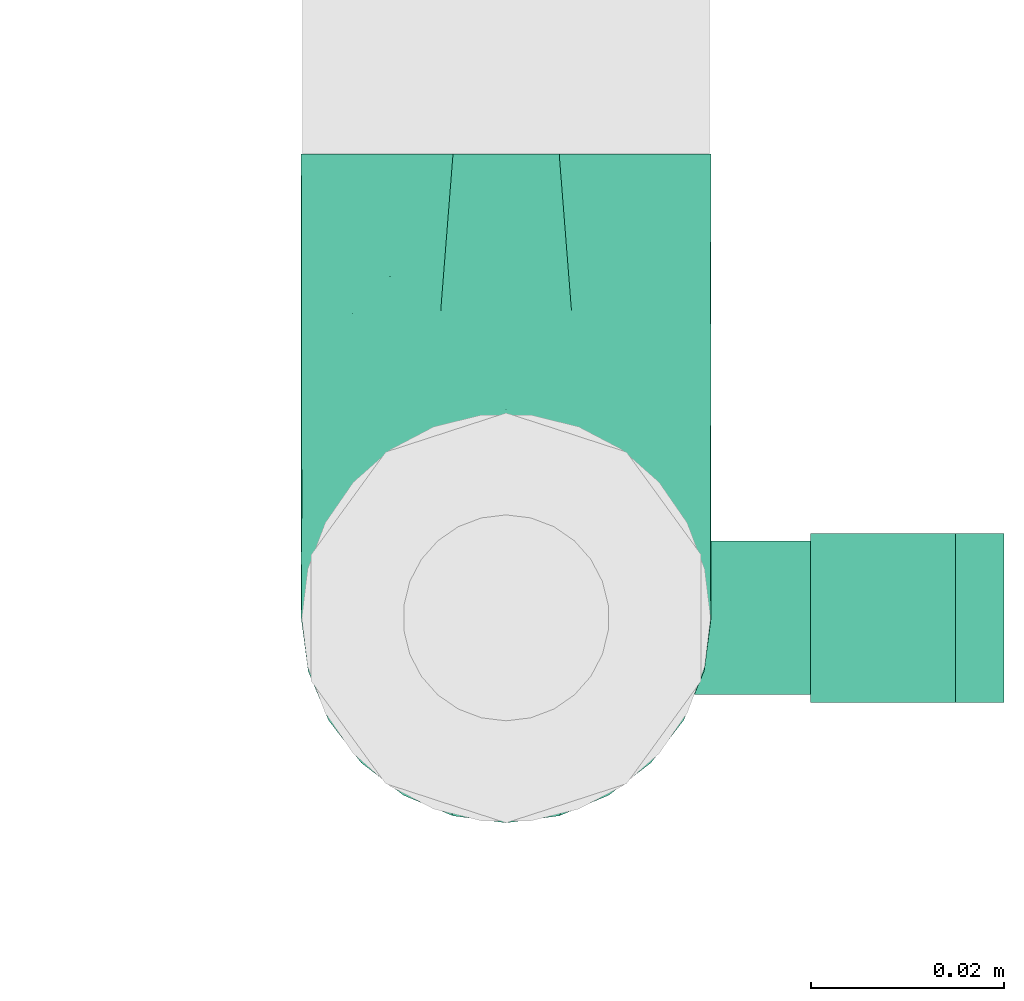
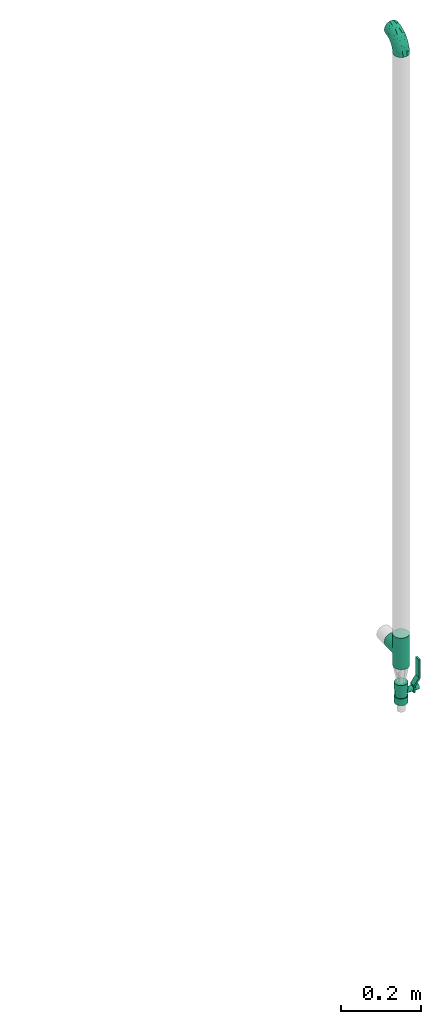
# One storey, part 76 of 93: 2 flow fittings, 1 flow controller.
"""IFC2X3 building model written with IfcOpenShell, lengths in millimetres."""

from ifc_helpers import new_model, entity, si_unit, converted_unit, derived_unit, direction, frame, origin, origin_2d_with_axis, place, context, subcontext, project, spatial, polyline, circle, outline, extrude, faceted_brep, source, transform, mapped, material, material_list, type_object, type_shapes, element, save


model = new_model("IFC2X3")

# Units and contexts
model_context = context("Model", 3, precision=0.01, world=origin(), true_north=direction((6.12303176911189e-17, 1.0)))
body_context = subcontext(model_context, "Body", "Model", "MODEL_VIEW")
ifc_project = project(units=[si_unit("LENGTHUNIT", "METRE", prefix="MILLI"), si_unit("AREAUNIT", "SQUARE_METRE"), si_unit("VOLUMEUNIT", "CUBIC_METRE"), converted_unit("PLANEANGLEUNIT", "DEGREE", entity("IfcRatioMeasure", 0.0174532925199433), si_unit("PLANEANGLEUNIT", "RADIAN"), dimensions=[0, 0, 0, 0, 0, 0, 0]), si_unit("MASSUNIT", "GRAM", prefix="KILO"), derived_unit("MASSDENSITYUNIT", [(si_unit("MASSUNIT", "GRAM", prefix="KILO"), 1), (si_unit("LENGTHUNIT", "METRE"), -3)]), derived_unit("MOMENTOFINERTIAUNIT", [(si_unit("LENGTHUNIT", "METRE"), 4)]), si_unit("TIMEUNIT", "SECOND"), si_unit("FREQUENCYUNIT", "HERTZ"), si_unit("THERMODYNAMICTEMPERATUREUNIT", "DEGREE_CELSIUS"), derived_unit("THERMALTRANSMITTANCEUNIT", [(si_unit("MASSUNIT", "GRAM", prefix="KILO"), 1), (si_unit("THERMODYNAMICTEMPERATUREUNIT", "KELVIN"), -1), (si_unit("TIMEUNIT", "SECOND"), -3)]), derived_unit("VOLUMETRICFLOWRATEUNIT", [(si_unit("LENGTHUNIT", "METRE"), 3), (si_unit("TIMEUNIT", "SECOND"), -1)]), derived_unit("MASSFLOWRATEUNIT", [(si_unit("MASSUNIT", "GRAM", prefix="KILO"), 1), (si_unit("TIMEUNIT", "SECOND"), -1)]), derived_unit("ROTATIONALFREQUENCYUNIT", [(si_unit("TIMEUNIT", "SECOND"), -1)]), si_unit("ELECTRICCURRENTUNIT", "AMPERE"), si_unit("ELECTRICVOLTAGEUNIT", "VOLT"), si_unit("POWERUNIT", "WATT"), si_unit("FORCEUNIT", "NEWTON", prefix="KILO"), si_unit("ILLUMINANCEUNIT", "LUX"), si_unit("LUMINOUSFLUXUNIT", "LUMEN"), si_unit("LUMINOUSINTENSITYUNIT", "CANDELA"), derived_unit("USERDEFINED", [(si_unit("MASSUNIT", "GRAM", prefix="KILO"), -1), (si_unit("LENGTHUNIT", "METRE"), -2), (si_unit("TIMEUNIT", "SECOND"), 3), (si_unit("LUMINOUSFLUXUNIT", "LUMEN"), 1)]), derived_unit("LINEARVELOCITYUNIT", [(si_unit("LENGTHUNIT", "METRE"), 1), (si_unit("TIMEUNIT", "SECOND"), -1)]), si_unit("PRESSUREUNIT", "PASCAL"), derived_unit("USERDEFINED", [(si_unit("LENGTHUNIT", "METRE"), -2), (si_unit("MASSUNIT", "GRAM", prefix="KILO"), 1), (si_unit("TIMEUNIT", "SECOND"), -2)]), derived_unit("LINEARFORCEUNIT", [(si_unit("MASSUNIT", "GRAM", prefix="KILO"), 1), (si_unit("LENGTHUNIT", "METRE"), 1), (si_unit("TIMEUNIT", "SECOND"), -2), (si_unit("LENGTHUNIT", "METRE"), -1)]), derived_unit("PLANARFORCEUNIT", [(si_unit("MASSUNIT", "GRAM", prefix="KILO"), 1), (si_unit("LENGTHUNIT", "METRE"), 1), (si_unit("TIMEUNIT", "SECOND"), -2), (si_unit("LENGTHUNIT", "METRE"), -2)])], contexts=[model_context])

# Site, building, storey
site_placement = place(None, origin())
site = spatial("IfcSite", under=ifc_project, at=site_placement, CompositionType="ELEMENT")
building_placement = place(site_placement, origin())
building = spatial("IfcBuilding", under=site, at=building_placement, CompositionType="ELEMENT")
storey_placement = place(building_placement, frame((0.0, 0.0, -4200.0)))
storey = spatial("IfcBuildingStorey", under=building, at=storey_placement, CompositionType="ELEMENT", Elevation=-4200.0)

# Flow controller
ifc_material = material()
ifc_material_list = material_list([ifc_material, ifc_material, ifc_material, ifc_material, ifc_material])
valve_type = type_object("IfcValveType", PredefinedType="NOTDEFINED", material=ifc_material_list)
shared_shape_1 = source(origin(), body_context, "Body", "SweptSolid", [
    extrude(circle(Radius=17.5, at=origin_2d_with_axis()), frame((-30.5, 0.0, 0.0), z_axis=(1.0, 0.0, 0.0), x_axis=(0.0, 1.0, 0.0)), (0.0, 0.0, 1.0), 20.3333333333333),
    extrude(circle(Radius=16.0, at=origin_2d_with_axis()), frame((-10.17, 0.0, 0.0), z_axis=(1.0, 0.0, 0.0), x_axis=(0.0, 1.0, 0.0)), (0.0, 0.0, 1.0), 20.3333333333333),
    extrude(circle(Radius=17.5, at=origin_2d_with_axis()), frame((10.17, 0.0, 0.0), z_axis=(1.0, 0.0, 0.0), x_axis=(0.0, 1.0, 0.0)), (0.0, 0.0, 1.0), 20.3333333333333),
    extrude(outline(polyline([(-38.75, -5.0), (-38.75, -10.0), (-17.92, -10.0), (2.08, 5.0), (56.25, 5.0), (56.25, 10.0), (0.42, 10.0), (-19.58, -5.0), (-38.75, -5.0)])), frame((28.75, -8.75, 41.5), z_axis=(0.0, -1.0, 0.0), x_axis=(1.0, 0.0, 0.0)), (0.0, 0.0, -1.0), 17.5),
    extrude(circle(Radius=8.0, at=origin_2d_with_axis()), origin(), (0.0, 0.0, 1.0), 49.0),
])
type_shapes(valve_type, [shared_shape_1])
flow_controller_placement = place(storey_placement, frame((60113.17, 18671.47, 32740.0), z_axis=(1.0, 0.0, 0.0), x_axis=(0.0, 0.0, 1.0)))
element("IfcFlowController", 1, at=flow_controller_placement, inside=storey, type_object=valve_type, material=ifc_material, context=body_context, shape_type="MappedRepresentation", body=[
    mapped(shared_shape_1, transform((0.0, 0.0, 0.0), scale=1.0)),
])

# Flow fittings
pipe_fitting_type_1 = type_object("IfcPipeFittingType", Name="ADSK_1", PredefinedType="NOTDEFINED", material=ifc_material)
shared_shape_2 = source(origin(), body_context, "Body", "Brep", [
    faceted_brep([(-48.0, 10.6, -18.36), (-48.0, 5.49, -20.48), (-48.0, 0.0, -21.2), (-48.0, -5.49, -20.48), (-48.0, -10.6, -18.36), (-48.0, -14.99, -14.99), (-48.0, -18.36, -10.6), (-48.0, -20.48, -5.49), (-48.0, -21.2, 0.0), (-48.0, -20.48, 5.49), (-48.0, -18.36, 10.6), (-48.0, -14.99, 14.99), (-48.0, -10.6, 18.36), (-48.0, -5.49, 20.48), (-48.0, 0.0, 21.2), (-48.0, 5.49, 20.48), (-48.0, 10.6, 18.36), (-48.0, 14.99, 14.99), (-48.0, 18.36, 10.6), (-48.0, 20.48, 5.49), (-48.0, 21.2, 0.0), (-48.0, 20.48, -5.49), (-48.0, 18.36, -10.6), (-48.0, 14.99, -14.99), (0.0, 48.0, -21.2), (-5.49, 48.0, -20.48), (-10.6, 48.0, -18.36), (-14.99, 48.0, -14.99), (-18.36, 48.0, -10.6), (-20.48, 48.0, -5.49), (-21.2, 48.0, 0.0), (-20.48, 48.0, 5.49), (-18.36, 48.0, 10.6), (-14.99, 48.0, 14.99), (-10.6, 48.0, 18.36), (-5.49, 48.0, 20.48), (0.0, 48.0, 21.2), (5.49, 48.0, 20.48), (10.6, 48.0, 18.36), (14.99, 48.0, 14.99), (18.36, 48.0, 10.6), (20.48, 48.0, 5.49), (21.2, 48.0, 0.0), (20.48, 48.0, -5.49), (18.36, 48.0, -10.6), (14.99, 48.0, -14.99), (10.6, 48.0, -18.36), (5.49, 48.0, -20.48), (-35.25, -16.22, 12.01), (-34.76, -18.57, 0.0), (-20.87, -12.37, 10.9), (-31.49, -11.78, 15.9), (-37.0, -2.58, 20.86), (-33.89, 3.62, 21.15), (-31.81, -18.14, 6.76), (-5.78, 5.78, 17.67), (-19.42, -4.1, 17.86), (-9.6, -3.39, 13.73), (-35.44, -7.73, 19.13), (11.78, 31.49, 15.9), (-5.93, -5.46, 6.95), (-18.45, -13.78, 5.46), (-10.29, -8.43, 0.0), (-24.6, 0.55, 20.62), (-37.28, 17.94, 13.81), (-33.38, 22.85, 9.59), (-41.46, 20.06, 8.75), (-29.51, 20.45, 15.16), (-15.04, 10.79, 21.13), (-7.08, 16.98, 20.93), (-8.39, 23.51, 21.15), (-40.86, 13.03, 17.26), (-8.05, 41.26, 19.83), (-3.21, 35.97, 21.14), (8.53, 19.66, 14.74), (4.1, 19.42, 17.86), (-37.72, 22.66, 4.78), (-37.07, 8.58, 19.98), (-13.0, 5.43, 19.97), (-3.78, 13.93, 19.7), (3.02, 8.69, 13.43), (-2.27, -0.05, 10.65), (6.22, 6.99, 7.09), (-22.25, 34.6, 9.45), (18.14, 31.81, 6.76), (16.22, 35.25, 12.01), (12.37, 20.87, 10.9), (7.73, 35.44, 19.13), (-21.52, -15.93, 0.0), (2.58, 37.0, 20.86), (18.57, 34.76, 0.0), (13.78, 18.45, 5.46), (15.93, 21.52, 0.0), (-20.03, -8.54, 14.9), (-28.6, 28.6, 5.16), (-24.79, 34.6, 0.0), (-34.6, 24.79, 0.0), (-22.81, 37.41, 4.68), (-23.36, 26.33, 14.79), (-13.68, 37.05, 17.49), (-17.72, 38.12, 13.73), (-26.25, 27.3, 11.24), (-9.71, 32.34, 20.14), (-17.26, 25.6, 18.71), (-26.33, 9.99, 20.77), (-24.06, 6.05, 21.2), (-25.02, 15.46, 19.56), (-24.3, 20.72, 17.57), (-31.95, 15.23, 17.8), (-13.53, 24.7, 20.21), (-17.6, 17.6, 20.6), (-0.55, 24.6, 20.62), (-11.41, -7.48, 10.43), (0.93, -0.93, 0.0), (8.43, 10.29, 0.0), (-11.41, -7.48, -10.43), (-20.1, -8.84, -14.66), (-9.6, -3.39, -13.73), (7.73, 35.44, -19.13), (4.1, 19.42, -17.86), (-0.55, 24.6, -20.62), (-38.12, 17.72, -13.73), (-37.05, 13.68, -17.49), (-32.34, 9.71, -20.14), (-41.26, 8.05, -19.83), (-37.41, 22.81, -4.68), (-23.51, 8.39, -21.15), (-35.97, 3.21, -21.14), (-28.6, 28.6, -5.16), (-31.81, -18.14, -6.76), (-18.45, -13.78, -5.46), (-25.6, 17.26, -18.71), (-19.42, -4.1, -17.86), (-17.94, 37.28, -13.81), (-22.85, 33.38, -9.59), (-20.06, 41.46, -8.75), (-31.49, -11.78, -15.9), (-35.25, -16.22, -12.01), (8.53, 19.66, -14.74), (11.78, 31.49, -15.9), (-9.99, 26.33, -20.77), (-6.05, 24.06, -21.2), (-10.79, 15.04, -21.13), (-37.0, -2.58, -20.86), (-16.98, 7.08, -20.93), (-5.43, 13.0, -19.97), (-13.93, 3.78, -19.7), (-20.87, -12.37, -10.9), (-26.33, 23.36, -14.79), (-22.66, 37.72, -4.78), (13.78, 18.45, -5.46), (18.14, 31.81, -6.76), (-15.46, 25.02, -19.56), (-20.72, 24.3, -17.57), (16.22, 35.25, -12.01), (-13.03, 40.86, -17.26), (-8.58, 37.07, -19.98), (2.58, 37.0, -20.86), (-3.62, 33.89, -21.15), (-34.6, 22.25, -9.45), (6.22, 6.99, -7.09), (-20.45, 29.51, -15.16), (-35.44, -7.73, -19.13), (12.37, 20.87, -10.9), (-27.3, 26.25, -11.24), (-15.23, 31.95, -17.8), (-24.7, 13.53, -20.21), (-24.6, 0.55, -20.62), (-5.78, 5.78, -17.67), (-17.6, 17.6, -20.6), (3.02, 8.69, -13.43), (-5.93, -5.46, -6.95), (-2.27, -0.05, -10.65)], [[[0, 1, 2, 3, 4, 5, 6, 7, 8, 9, 10, 11, 12, 13, 14, 15, 16, 17, 18, 19, 20, 21, 22, 23]], [[24, 25, 26, 27, 28, 29, 30, 31, 32, 33, 34, 35, 36, 37, 38, 39, 40, 41, 42, 43, 44, 45, 46, 47]], [[10, 48, 11]], [[9, 8, 49]], [[48, 50, 51]], [[14, 52, 53]], [[10, 54, 48]], [[9, 54, 10]], [[55, 56, 57]], [[51, 12, 11]], [[51, 58, 12]], [[59, 39, 38]], [[60, 61, 62]], [[58, 56, 63]], [[64, 65, 66]], [[67, 65, 64]], [[68, 69, 70]], [[16, 71, 17]], [[13, 52, 14]], [[35, 72, 73]], [[14, 53, 15]], [[17, 64, 18]], [[74, 59, 75]], [[20, 19, 76]], [[66, 19, 18]], [[77, 15, 53]], [[15, 77, 16]], [[69, 78, 79]], [[80, 81, 82]], [[32, 31, 83]], [[84, 85, 86]], [[59, 87, 75]], [[61, 54, 88]], [[36, 89, 37]], [[84, 41, 40]], [[36, 35, 73]], [[90, 41, 84]], [[40, 39, 85]], [[12, 58, 13]], [[85, 84, 40]], [[91, 84, 86]], [[84, 92, 90]], [[87, 38, 37]], [[93, 56, 51]], [[65, 94, 76]], [[94, 95, 96]], [[84, 91, 92]], [[95, 97, 30]], [[98, 99, 100]], [[76, 94, 96]], [[101, 98, 83]], [[100, 99, 33]], [[102, 70, 73]], [[103, 102, 99]], [[94, 97, 95]], [[72, 99, 102]], [[72, 35, 34]], [[34, 33, 99]], [[9, 49, 54]], [[87, 59, 38]], [[104, 105, 68]], [[106, 103, 107]], [[106, 77, 104]], [[71, 64, 17]], [[108, 107, 67]], [[33, 32, 100]], [[109, 103, 110]], [[102, 109, 70]], [[89, 73, 111]], [[50, 48, 54]], [[51, 11, 48]], [[56, 58, 51]], [[88, 54, 49]], [[52, 58, 63]], [[50, 112, 93]], [[56, 55, 78]], [[39, 59, 85]], [[86, 85, 59]], [[89, 87, 37]], [[42, 41, 90]], [[111, 79, 75]], [[111, 75, 87]], [[75, 55, 80]], [[104, 77, 53]], [[71, 77, 108]], [[32, 83, 100]], [[98, 100, 83]], [[99, 98, 103]], [[106, 107, 108]], [[68, 70, 110]], [[111, 73, 70]], [[68, 110, 104]], [[68, 63, 78]], [[57, 93, 112]], [[80, 55, 57]], [[61, 50, 54]], [[80, 82, 86]], [[81, 57, 112]], [[74, 86, 59]], [[60, 113, 82]], [[82, 114, 91]], [[101, 94, 65]], [[97, 94, 83]], [[73, 89, 36]], [[87, 89, 111]], [[58, 52, 13]], [[53, 52, 63]], [[104, 53, 105]], [[106, 104, 110]], [[20, 76, 96]], [[76, 19, 66]], [[103, 106, 110]], [[77, 106, 108]], [[103, 98, 107]], [[67, 107, 98]], [[67, 98, 101]], [[108, 67, 64]], [[53, 63, 105]], [[63, 68, 105]], [[83, 31, 97]], [[30, 97, 31]], [[62, 113, 60]], [[112, 61, 60]], [[61, 88, 62]], [[86, 82, 91]], [[56, 78, 63]], [[114, 82, 113]], [[114, 92, 91]], [[79, 78, 55]], [[75, 79, 55]], [[69, 79, 111]], [[70, 69, 111]], [[78, 69, 68]], [[77, 71, 16]], [[64, 71, 108]], [[64, 66, 18]], [[76, 66, 65]], [[99, 72, 34]], [[73, 72, 102]], [[94, 101, 83]], [[67, 101, 65]], [[75, 80, 74]], [[80, 86, 74]], [[70, 109, 110]], [[102, 103, 109]], [[50, 93, 51]], [[57, 56, 93]], [[61, 112, 50]], [[81, 112, 60]], [[82, 81, 60]], [[80, 57, 81]], [[115, 116, 117]], [[118, 119, 120]], [[121, 122, 23]], [[123, 124, 122]], [[96, 125, 20]], [[123, 126, 127]], [[128, 96, 95]], [[129, 130, 88]], [[123, 122, 131]], [[116, 132, 117]], [[133, 134, 135]], [[0, 124, 1]], [[5, 136, 137]], [[138, 119, 139]], [[129, 88, 49]], [[140, 141, 142]], [[6, 5, 137]], [[46, 118, 47]], [[143, 3, 2]], [[144, 145, 146]], [[6, 129, 7]], [[129, 137, 147]], [[127, 2, 1]], [[148, 122, 121]], [[128, 125, 96]], [[134, 128, 149]], [[95, 149, 128]], [[150, 151, 92]], [[30, 29, 149]], [[152, 131, 153]], [[27, 133, 28]], [[154, 45, 44]], [[136, 5, 4]], [[27, 26, 155]], [[156, 26, 25]], [[24, 157, 158]], [[24, 47, 157]], [[22, 21, 159]], [[160, 150, 114]], [[134, 133, 161]], [[142, 144, 126]], [[46, 139, 118]], [[162, 136, 4]], [[156, 25, 158]], [[1, 124, 127]], [[115, 147, 116]], [[45, 154, 139]], [[139, 46, 45]], [[154, 163, 139]], [[162, 4, 3]], [[42, 90, 43]], [[130, 129, 147]], [[49, 7, 129]], [[43, 151, 44]], [[0, 23, 122]], [[24, 158, 25]], [[136, 162, 132]], [[135, 29, 28]], [[43, 90, 151]], [[164, 148, 159]], [[152, 156, 140]], [[155, 133, 27]], [[165, 153, 161]], [[23, 22, 121]], [[123, 131, 166]], [[123, 166, 126]], [[143, 127, 167]], [[147, 137, 136]], [[8, 7, 49]], [[129, 6, 137]], [[143, 162, 3]], [[167, 146, 132]], [[167, 132, 162]], [[132, 168, 117]], [[44, 151, 154]], [[92, 151, 90]], [[163, 154, 151]], [[119, 118, 139]], [[157, 118, 120]], [[138, 139, 163]], [[119, 168, 145]], [[140, 156, 158]], [[155, 156, 165]], [[22, 159, 121]], [[148, 121, 159]], [[122, 148, 131]], [[152, 153, 165]], [[142, 126, 169]], [[167, 127, 126]], [[142, 169, 140]], [[142, 120, 145]], [[168, 170, 117]], [[160, 171, 172]], [[115, 172, 171]], [[171, 62, 130]], [[119, 170, 168]], [[170, 163, 160]], [[150, 163, 151]], [[113, 171, 160]], [[164, 128, 134]], [[125, 128, 159]], [[127, 143, 2]], [[162, 143, 167]], [[118, 157, 47]], [[158, 157, 120]], [[140, 158, 141]], [[152, 140, 169]], [[30, 149, 95]], [[149, 29, 135]], [[131, 152, 169]], [[156, 152, 165]], [[131, 148, 153]], [[161, 153, 148]], [[161, 148, 164]], [[165, 161, 133]], [[158, 120, 141]], [[120, 142, 141]], [[159, 21, 125]], [[20, 125, 21]], [[115, 130, 147]], [[114, 113, 160]], [[62, 171, 113]], [[62, 88, 130]], [[160, 163, 150]], [[150, 92, 114]], [[119, 145, 120]], [[146, 145, 168]], [[132, 146, 168]], [[144, 146, 167]], [[126, 144, 167]], [[145, 144, 142]], [[156, 155, 26]], [[133, 155, 165]], [[133, 135, 28]], [[149, 135, 134]], [[122, 124, 0]], [[127, 124, 123]], [[128, 164, 159]], [[161, 164, 134]], [[163, 170, 138]], [[170, 119, 138]], [[131, 169, 166]], [[126, 166, 169]], [[147, 136, 116]], [[132, 116, 136]], [[172, 115, 117]], [[130, 115, 171]], [[117, 170, 172]], [[160, 172, 170]]]),
])
type_shapes(pipe_fitting_type_1, [shared_shape_2])
flow_fitting_1_placement = place(storey_placement, frame((60113.17, 18671.47, 34734.74), z_axis=(-1.0, 0.0, 0.0), x_axis=(0.0, 0.0, 1.0)))
element("IfcFlowFitting", 2, at=flow_fitting_1_placement, inside=storey, type_object=pipe_fitting_type_1, material=ifc_material, Name="ADSK_1", ObjectType="ADSK_1", context=body_context, shape_type="MappedRepresentation", body=[
    mapped(shared_shape_2, transform((0.0, 0.0, 0.0), scale=1.0)),
])
pipe_fitting_type_2 = type_object("IfcPipeFittingType", Name="ADSK_1", PredefinedType="NOTDEFINED", material=ifc_material)
shared_shape_3 = source(origin(), body_context, "Body", "Brep", [
    faceted_brep([(-48.0, 10.6, -18.36), (-48.0, 5.49, -20.48), (-48.0, 0.0, -21.2), (-48.0, -5.49, -20.48), (-48.0, -10.6, -18.36), (-48.0, -14.99, -14.99), (-48.0, -18.36, -10.6), (-48.0, -20.48, -5.49), (-48.0, -21.2, 0.0), (-48.0, -20.48, 5.49), (-48.0, -18.36, 10.6), (-48.0, -14.99, 14.99), (-48.0, -10.6, 18.36), (-48.0, -5.49, 20.48), (-48.0, 0.0, 21.2), (-48.0, 5.49, 20.48), (-48.0, 10.6, 18.36), (-48.0, 14.99, 14.99), (-48.0, 18.36, 10.6), (-48.0, 20.48, 5.49), (-48.0, 21.2, 0.0), (-48.0, 20.48, -5.49), (-48.0, 18.36, -10.6), (-48.0, 14.99, -14.99), (48.0, 0.0, -21.2), (48.0, 5.49, -20.48), (48.0, 10.6, -18.36), (48.0, 14.99, -14.99), (48.0, 18.36, -10.6), (48.0, 20.48, -5.49), (48.0, 21.2, 0.0), (48.0, 20.48, 5.49), (48.0, 18.36, 10.6), (48.0, 14.99, 14.99), (48.0, 10.6, 18.36), (48.0, 5.49, 20.48), (48.0, 0.0, 21.2), (48.0, -5.49, 20.48), (48.0, -10.6, 18.36), (48.0, -14.99, 14.99), (48.0, -18.36, 10.6), (48.0, -20.48, 5.49), (48.0, -21.2, 0.0), (48.0, -20.48, -5.49), (48.0, -18.36, -10.6), (48.0, -14.99, -14.99), (48.0, -10.6, -18.36), (48.0, -5.49, -20.48), (20.43, -20.43, 5.66), (21.2, -21.2, 0.0), (-21.2, -21.2, 0.0), (18.35, -18.35, 10.62), (11.88, -11.88, 17.56), (15.38, -15.38, 14.59), (-20.43, -20.43, 5.66), (-18.35, -18.35, 10.62), (-15.38, -15.38, 14.59), (-11.88, -11.88, 17.56), (-8.06, -8.06, 19.61), (8.06, -8.06, 19.61), (4.07, -4.07, 20.81), (0.0, 0.0, 21.2), (-4.07, -4.07, 20.81), (4.07, -4.07, -20.81), (0.0, 0.0, -21.2), (-4.07, -4.07, -20.81), (-8.06, -8.06, -19.61), (8.06, -8.06, -19.61), (11.88, -11.88, -17.56), (15.38, -15.38, -14.59), (18.35, -18.35, -10.62), (20.43, -20.43, -5.66), (-11.88, -11.88, -17.56), (-15.38, -15.38, -14.59), (-20.43, -20.43, -5.66), (-18.35, -18.35, -10.62), (0.0, -48.0, -21.2), (5.49, -48.0, -20.48), (10.6, -48.0, -18.36), (14.99, -48.0, -14.99), (18.36, -48.0, -10.6), (20.48, -48.0, -5.49), (21.2, -48.0, 0.0), (20.48, -48.0, 5.49), (18.36, -48.0, 10.6), (14.99, -48.0, 14.99), (10.6, -48.0, 18.36), (5.49, -48.0, 20.48), (0.0, -48.0, 21.2), (-5.49, -48.0, 20.48), (-10.6, -48.0, 18.36), (-14.99, -48.0, 14.99), (-18.36, -48.0, 10.6), (-20.48, -48.0, 5.49), (-21.2, -48.0, 0.0), (-20.48, -48.0, -5.49), (-18.36, -48.0, -10.6), (-14.99, -48.0, -14.99), (-10.6, -48.0, -18.36), (-5.49, -48.0, -20.48)], [[[0, 1, 2, 3, 4, 5, 6, 7, 8, 9, 10, 11, 12, 13, 14, 15, 16, 17, 18, 19, 20, 21, 22, 23]], [[24, 25, 26, 27, 28, 29, 30, 31, 32, 33, 34, 35, 36, 37, 38, 39, 40, 41, 42, 43, 44, 45, 46, 47]], [[41, 40, 48]], [[42, 41, 49]], [[50, 9, 8]], [[49, 41, 48]], [[40, 51, 48]], [[39, 38, 52]], [[51, 40, 53]], [[52, 53, 39]], [[53, 40, 39]], [[50, 54, 9]], [[9, 54, 10]], [[54, 55, 10]], [[56, 57, 11]], [[11, 10, 56]], [[11, 57, 12]], [[56, 10, 55]], [[12, 57, 58]], [[52, 38, 59]], [[60, 36, 61]], [[62, 61, 14]], [[59, 37, 60]], [[37, 59, 38]], [[60, 37, 36]], [[61, 36, 35, 15, 14]], [[32, 31, 19, 18]], [[17, 16, 34, 33]], [[18, 17, 33, 32]], [[35, 34, 16, 15]], [[20, 19, 31, 30]], [[62, 13, 58]], [[13, 62, 14]], [[58, 13, 12]], [[27, 23, 22, 28]], [[22, 21, 29, 28]], [[0, 23, 27, 26]], [[20, 30, 29, 21]], [[24, 47, 63]], [[24, 64, 2, 1, 25]], [[64, 24, 63]], [[2, 64, 65]], [[26, 25, 1, 0]], [[65, 66, 3]], [[2, 65, 3]], [[66, 4, 3]], [[63, 47, 67]], [[46, 45, 68]], [[69, 68, 45]], [[44, 70, 69]], [[69, 45, 44]], [[46, 68, 67]], [[43, 42, 49]], [[7, 50, 8]], [[43, 71, 44]], [[71, 43, 49]], [[44, 71, 70]], [[72, 4, 66]], [[72, 5, 4]], [[5, 72, 73]], [[5, 73, 6]], [[74, 50, 7]], [[75, 74, 6]], [[74, 7, 6]], [[75, 6, 73]], [[46, 67, 47]], [[76, 77, 78, 79, 80, 81, 82, 83, 84, 85, 86, 87, 88, 89, 90, 91, 92, 93, 94, 95, 96, 97, 98, 99]], [[50, 94, 93]], [[54, 50, 93]], [[91, 90, 57]], [[56, 92, 91]], [[54, 93, 92]], [[58, 90, 89]], [[55, 54, 92]], [[56, 55, 92]], [[58, 57, 90]], [[88, 61, 62]], [[58, 89, 62]], [[56, 91, 57]], [[62, 89, 88]], [[60, 88, 87]], [[86, 59, 87]], [[84, 83, 48]], [[53, 85, 84]], [[52, 86, 85]], [[49, 83, 82]], [[59, 60, 87]], [[52, 59, 86]], [[49, 48, 83]], [[51, 53, 84]], [[48, 51, 84]], [[52, 85, 53]], [[88, 60, 61]], [[82, 81, 49]], [[71, 49, 81]], [[69, 80, 79]], [[79, 78, 68]], [[71, 81, 80]], [[67, 78, 77]], [[70, 71, 80]], [[69, 70, 80]], [[67, 68, 78]], [[76, 64, 63]], [[67, 77, 63]], [[69, 79, 68]], [[63, 77, 76]], [[65, 76, 99]], [[98, 66, 99]], [[96, 95, 74]], [[73, 97, 96]], [[72, 98, 97]], [[50, 95, 94]], [[66, 65, 99]], [[72, 66, 98]], [[50, 74, 95]], [[75, 73, 96]], [[74, 75, 96]], [[72, 97, 73]], [[76, 65, 64]]]),
])
type_shapes(pipe_fitting_type_2, [shared_shape_3])
flow_fitting_2_placement = place(storey_placement, frame((60113.17, 18671.47, 32869.5), z_axis=(1.0, 0.0, 0.0), x_axis=(0.0, 0.0, 1.0)))
element("IfcFlowFitting", 3, at=flow_fitting_2_placement, inside=storey, type_object=pipe_fitting_type_2, material=ifc_material, Name="ADSK_1", ObjectType="ADSK_1", context=body_context, shape_type="MappedRepresentation", body=[
    mapped(shared_shape_3, transform((0.0, 0.0, 0.0), scale=1.0)),
])

save(model, "model.ifc")
